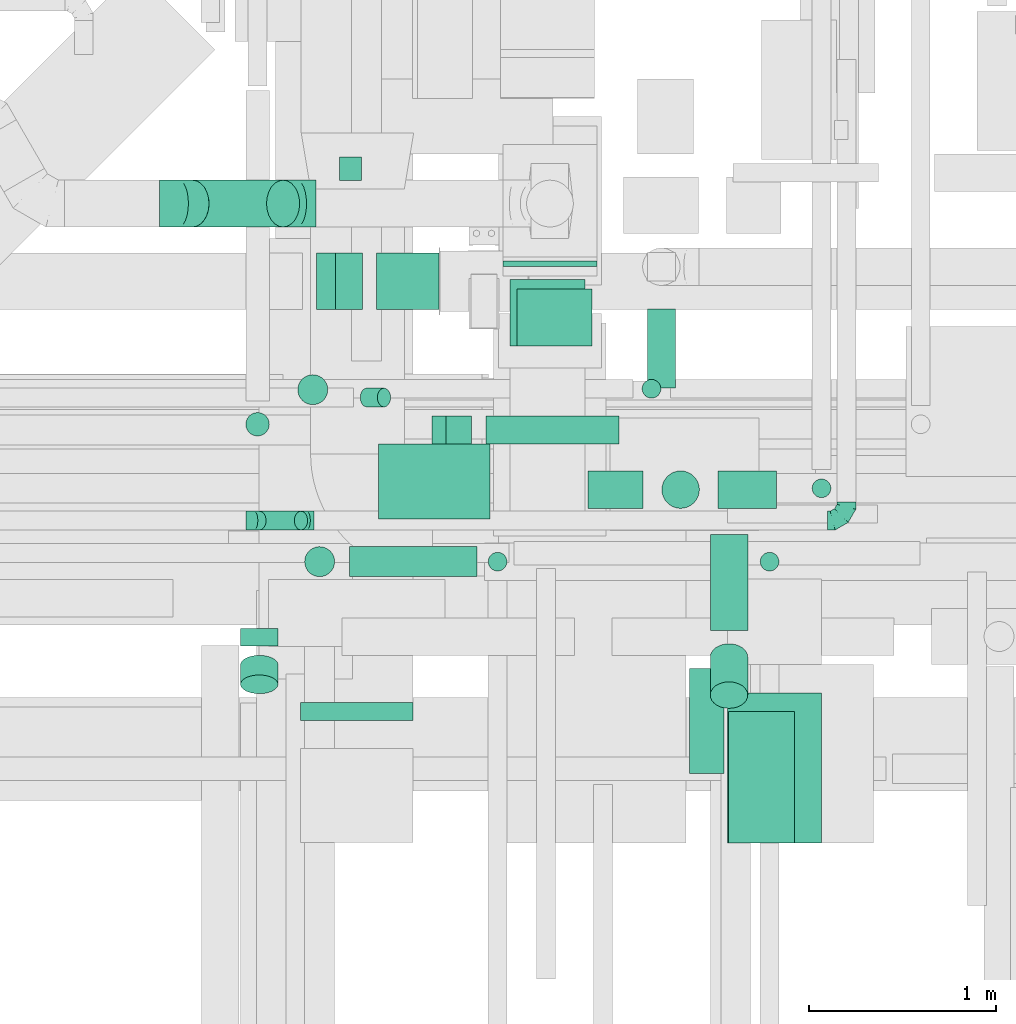
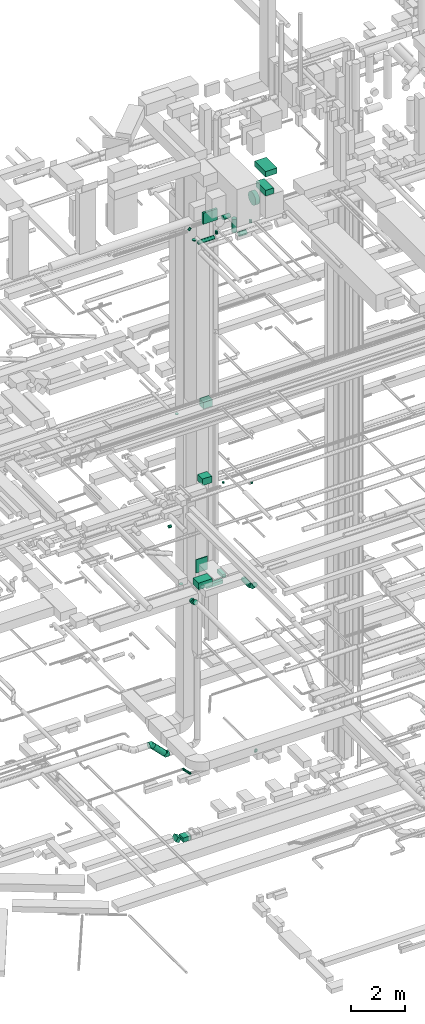
# One storey, part 128 of 337: 32 flow segments, 5 flow fittings.
"""IFC2X3 building model written with IfcOpenShell, lengths in millimetres."""

from ifc_helpers import new_model, entity, si_unit, converted_unit, derived_unit, direction, frame, frame_2d, origin, origin_2d_with_axis, place, context, subcontext, project, spatial, rectangle, circle, extrude, faceted_brep, source, transform, mapped, material, type_object, type_shapes, element, save


model = new_model("IFC2X3")

# Units and contexts
model_context = context("Model", 3, precision=0.01, world=origin(), true_north=direction((6.12303176911189e-17, 1.0)))
body_context = subcontext(model_context, "Body", "Model", "MODEL_VIEW")
ifc_project = project(units=[si_unit("LENGTHUNIT", "METRE", prefix="MILLI"), si_unit("AREAUNIT", "SQUARE_METRE"), si_unit("VOLUMEUNIT", "CUBIC_METRE"), converted_unit("PLANEANGLEUNIT", "DEGREE", entity("IfcRatioMeasure", 0.0174532925199433), si_unit("PLANEANGLEUNIT", "RADIAN"), dimensions=[0, 0, 0, 0, 0, 0, 0]), si_unit("MASSUNIT", "GRAM", prefix="KILO"), derived_unit("MASSDENSITYUNIT", [(si_unit("MASSUNIT", "GRAM", prefix="KILO"), 1), (si_unit("LENGTHUNIT", "METRE"), -3)]), derived_unit("MOMENTOFINERTIAUNIT", [(si_unit("LENGTHUNIT", "METRE"), 4)]), si_unit("TIMEUNIT", "SECOND"), si_unit("FREQUENCYUNIT", "HERTZ"), si_unit("THERMODYNAMICTEMPERATUREUNIT", "DEGREE_CELSIUS"), derived_unit("THERMALTRANSMITTANCEUNIT", [(si_unit("MASSUNIT", "GRAM", prefix="KILO"), 1), (si_unit("THERMODYNAMICTEMPERATUREUNIT", "KELVIN"), -1), (si_unit("TIMEUNIT", "SECOND"), -3)]), derived_unit("VOLUMETRICFLOWRATEUNIT", [(si_unit("LENGTHUNIT", "METRE"), 3), (si_unit("TIMEUNIT", "SECOND"), -1)]), derived_unit("MASSFLOWRATEUNIT", [(si_unit("MASSUNIT", "GRAM", prefix="KILO"), 1), (si_unit("TIMEUNIT", "SECOND"), -1)]), derived_unit("ROTATIONALFREQUENCYUNIT", [(si_unit("TIMEUNIT", "SECOND"), -1)]), si_unit("ELECTRICCURRENTUNIT", "AMPERE"), si_unit("ELECTRICVOLTAGEUNIT", "VOLT"), si_unit("POWERUNIT", "WATT"), si_unit("FORCEUNIT", "NEWTON", prefix="KILO"), si_unit("ILLUMINANCEUNIT", "LUX"), si_unit("LUMINOUSFLUXUNIT", "LUMEN"), si_unit("LUMINOUSINTENSITYUNIT", "CANDELA"), derived_unit("USERDEFINED", [(si_unit("MASSUNIT", "GRAM", prefix="KILO"), -1), (si_unit("LENGTHUNIT", "METRE"), -2), (si_unit("TIMEUNIT", "SECOND"), 3), (si_unit("LUMINOUSFLUXUNIT", "LUMEN"), 1)]), derived_unit("LINEARVELOCITYUNIT", [(si_unit("LENGTHUNIT", "METRE"), 1), (si_unit("TIMEUNIT", "SECOND"), -1)]), si_unit("PRESSUREUNIT", "PASCAL"), derived_unit("USERDEFINED", [(si_unit("LENGTHUNIT", "METRE"), -2), (si_unit("MASSUNIT", "GRAM", prefix="KILO"), 1), (si_unit("TIMEUNIT", "SECOND"), -2)]), derived_unit("LINEARFORCEUNIT", [(si_unit("MASSUNIT", "GRAM", prefix="KILO"), 1), (si_unit("LENGTHUNIT", "METRE"), 1), (si_unit("TIMEUNIT", "SECOND"), -2), (si_unit("LENGTHUNIT", "METRE"), -1)]), derived_unit("PLANARFORCEUNIT", [(si_unit("MASSUNIT", "GRAM", prefix="KILO"), 1), (si_unit("LENGTHUNIT", "METRE"), 1), (si_unit("TIMEUNIT", "SECOND"), -2), (si_unit("LENGTHUNIT", "METRE"), -2)])], contexts=[model_context])

# Site, building, storey
site_placement = place(None, origin())
site = spatial("IfcSite", under=ifc_project, at=site_placement, CompositionType="ELEMENT")
building_placement = place(site_placement, origin())
building = spatial("IfcBuilding", under=site, at=building_placement, CompositionType="ELEMENT")
storey_placement = place(building_placement, origin())
storey = spatial("IfcBuildingStorey", under=building, at=storey_placement, CompositionType="ELEMENT", Elevation=0.0)

# Flow segments
duct_segment_type_1 = type_object("IfcDuctSegmentType", PredefinedType="NOTDEFINED")
flow_segment_1_placement = place(storey_placement, frame((23416.99, 10670.0, -850.0)))
element("IfcFlowSegment", 1, at=flow_segment_1_placement, inside=storey, type_object=duct_segment_type_1, context=body_context, shape_type="SweptSolid", body=[
    extrude(rectangle(XDim=333.012703748609, YDim=300.000000000001, at=origin_2d_with_axis()), frame((166.51, 150.0, 0.0), z_axis=(0.0, 0.0, 1.0), x_axis=(-1.0, 0.0, 0.0)), (0.0, 0.0, 1.0), 200.0),
])
flow_segment_2_placement = place(storey_placement, frame((23427.3, 9550.83, 11250.0)))
element("IfcFlowSegment", 2, at=flow_segment_2_placement, inside=storey, type_object=duct_segment_type_1, context=body_context, shape_type="SweptSolid", body=[
    extrude(rectangle(XDim=594.99999999999, YDim=400.0, at=origin_2d_with_axis()), frame((297.5, 200.0, 0.0)), (0.0, 0.0, 1.0), 300.000000000001),
])
flow_segment_3_placement = place(storey_placement, frame((24861.21, 10251.69, 10850.0)))
element("IfcFlowSegment", 3, at=flow_segment_3_placement, inside=storey, type_object=duct_segment_type_1, context=body_context, shape_type="SweptSolid", body=[
    extrude(rectangle(XDim=420.860274633436, YDim=150.000000000001, at=origin_2d_with_axis()), frame((75.0, 210.43, 0.0), z_axis=(0.0, 0.0, 1.0), x_axis=(0.0, -1.0, 0.0)), (0.0, 0.0, 1.0), 150.000000000001),
])
flow_segment_4_placement = place(storey_placement, frame((23999.98, 9951.69, 10850.0)))
element("IfcFlowSegment", 4, at=flow_segment_4_placement, inside=storey, type_object=duct_segment_type_1, context=body_context, shape_type="SweptSolid", body=[
    extrude(rectangle(XDim=711.23519289757, YDim=150.000000000001, at=origin_2d_with_axis()), frame((355.62, 75.0, 0.0), z_axis=(0.0, 0.0, 1.0), x_axis=(-1.0, 0.0, 0.0)), (0.0, 0.0, 1.0), 150.000000000001),
])
flow_segment_5_placement = place(storey_placement, frame((24129.3, 10474.94, 15150.0)))
element("IfcFlowSegment", 5, at=flow_segment_5_placement, inside=storey, type_object=duct_segment_type_1, context=body_context, shape_type="SweptSolid", body=[
    extrude(rectangle(XDim=354.416495701594, YDim=400.0, at=origin_2d_with_axis()), frame((200.0, 177.21, 0.0), z_axis=(0.0, 0.0, 1.0), x_axis=(0.0, 1.0, 0.0)), (0.0, 0.0, 1.0), 300.000000000001),
])
flow_segment_6_placement = place(storey_placement, frame((24092.3, 10898.36, 10950.0)))
element("IfcFlowSegment", 6, at=flow_segment_6_placement, inside=storey, type_object=duct_segment_type_1, context=body_context, shape_type="SweptSolid", body=[
    extrude(rectangle(XDim=31.0000000000579, YDim=499.999999999999, at=origin_2d_with_axis()), frame((250.0, 15.5, 0.0), z_axis=(0.0, 0.0, 1.0), x_axis=(0.0, -1.0, 0.0)), (0.0, 0.0, 1.0), 600.000000000002),
])
flow_segment_7_placement = place(storey_placement, frame((24165.55, 10475.3, 18600.0)))
element("IfcFlowSegment", 7, at=flow_segment_7_placement, inside=storey, type_object=duct_segment_type_1, context=body_context, shape_type="SweptSolid", body=[
    extrude(rectangle(XDim=304.063774526682, YDim=400.0, at=origin_2d_with_axis()), frame((200.0, 152.03, 0.0), z_axis=(0.0, 0.0, 1.0), x_axis=(0.0, -1.0, 0.0)), (0.0, 0.0, 1.0), 300.000000000001),
])
flow_segment_8_placement = place(storey_placement, frame((23711.92, 9951.69, 10890.19)))
element("IfcFlowSegment", 8, at=flow_segment_8_placement, inside=storey, type_object=duct_segment_type_1, context=body_context, shape_type="SweptSolid", body=[
    extrude(rectangle(XDim=150.0, YDim=150.000000000001, at=origin_2d_with_axis()), frame((37.5, 75.0, 144.66), z_axis=(0.866025403784404, 0.0, -0.50000000000006), x_axis=(0.50000000000006, 0.0, 0.866025403784404)), (0.0, 0.0, 1.0), 159.422863405966),
])
flow_segment_9_placement = place(storey_placement, frame((23098.21, 10670.0, -803.11)))
element("IfcFlowSegment", 9, at=flow_segment_9_placement, inside=storey, type_object=duct_segment_type_1, context=body_context, shape_type="SweptSolid", body=[
    extrude(rectangle(XDim=200.000000000001, YDim=166.025414697291, at=frame_2d((0.0, 0.0), x_axis=(0.0, 1.0))), frame((121.89, 0.0, 128.11), z_axis=(0.0, 1.0, 0.0), x_axis=(-0.866025410712629, 0.0, 0.499999988000022)), (0.0, 0.0, 1.0), 300.000000000001),
])
duct_segment_type_2 = type_object("IfcDuctSegmentType", PredefinedType="NOTDEFINED")
flow_segment_10_placement = place(storey_placement, frame((22995.7, 10159.92, 11225.0)))
element("IfcFlowSegment", 10, at=flow_segment_10_placement, inside=storey, type_object=duct_segment_type_2, context=body_context, shape_type="SweptSolid", body=[
    extrude(circle(Radius=80.0, at=origin_2d_with_axis()), frame((81.6, 81.6, 0.0), z_axis=(0.0, 0.0, 1.0), x_axis=(0.0, 1.0, 0.0)), (0.0, 0.0, 1.0), 4.99999999988408),
])
flow_segment_11_placement = place(storey_placement, frame((22345.36, 11107.76, 2953.24)))
element("IfcFlowSegment", 11, at=flow_segment_11_placement, inside=storey, type_object=duct_segment_type_2, context=body_context, shape_type="SweptSolid", body=[
    extrude(circle(Radius=125.0, at=origin_2d_with_axis()), frame((573.54, 126.6, 89.98), z_axis=(-0.707106781186545, 0.0, 0.70710678118655), x_axis=(0.0, -1.0, 0.0)), (0.0, 0.0, 1.0), 683.847763108508),
])
flow_segment_12_placement = place(storey_placement, frame((22690.22, 8874.74, 11254.41)))
element("IfcFlowSegment", 12, at=flow_segment_12_placement, inside=storey, type_object=duct_segment_type_2, context=body_context, shape_type="SweptSolid", body=[
    extrude(circle(Radius=100.0, at=origin_2d_with_axis()), frame((101.6, 0.0, 101.6), z_axis=(0.0, 1.0, 0.0), x_axis=(-1.0, 0.0, 0.0)), (0.0, 0.0, 1.0), 93.1351932953009),
])
flow_segment_13_placement = place(storey_placement, frame((22690.22, 8618.52, 11294.6)))
element("IfcFlowSegment", 13, at=flow_segment_13_placement, inside=storey, type_object=duct_segment_type_2, context=body_context, shape_type="SweptSolid", body=[
    extrude(circle(Radius=100.0, at=origin_2d_with_axis()), frame((101.6, 156.22, 88.2), z_axis=(0.0, -0.86602530090874, 0.500000178185895), x_axis=(-1.0, 0.0, 0.0)), (0.0, 0.0, 1.0), 120.810096405886),
])
flow_segment_14_placement = place(storey_placement, frame((25195.7, 8956.91, 11048.4)))
element("IfcFlowSegment", 14, at=flow_segment_14_placement, inside=storey, type_object=duct_segment_type_2, context=body_context, shape_type="SweptSolid", body=[
    extrude(circle(Radius=100.0, at=origin_2d_with_axis()), frame((101.6, 0.0, 101.6), z_axis=(0.0, 1.0, 0.0), x_axis=(-1.0, 0.0, 0.0)), (0.0, 0.0, 1.0), 513.631879125135),
])
flow_segment_15_placement = place(storey_placement, frame((25195.7, 8540.34, 11136.27)))
element("IfcFlowSegment", 15, at=flow_segment_15_placement, inside=storey, type_object=duct_segment_type_2, context=body_context, shape_type="SweptSolid", body=[
    extrude(circle(Radius=100.0, at=origin_2d_with_axis()), frame((101.6, 275.15, 72.31), z_axis=(0.0, -0.707106781186528, 0.707106781186567), x_axis=(-1.0, 0.0, 0.0)), (0.0, 0.0, 1.0), 286.862915010188),
])
flow_segment_16_placement = place(storey_placement, frame((23219.15, 11355.44, 12973.4)))
element("IfcFlowSegment", 16, at=flow_segment_16_placement, inside=storey, type_object=duct_segment_type_2, context=body_context, shape_type="SweptSolid", body=[
    extrude(circle(Radius=62.5, at=origin_2d_with_axis()), frame((0.0, 64.1, 64.1), z_axis=(1.0, 0.0, 0.0), x_axis=(0.0, 1.0, 0.0)), (0.0, 0.0, 1.0), 117.499999999999),
])
flow_segment_17_placement = place(storey_placement, frame((24832.43, 10194.7, 15150.0)))
element("IfcFlowSegment", 17, at=flow_segment_17_placement, inside=storey, type_object=duct_segment_type_2, context=body_context, shape_type="SweptSolid", body=[
    extrude(circle(Radius=50.0, at=origin_2d_with_axis()), frame((51.6, 51.6, 0.0), z_axis=(0.0, 0.0, 1.0), x_axis=(0.0, -1.0, 0.0)), (0.0, 0.0, 1.0), 49.999999999993),
])
flow_segment_18_placement = place(storey_placement, frame((25739.15, 9664.09, 15150.0)))
element("IfcFlowSegment", 18, at=flow_segment_18_placement, inside=storey, type_object=duct_segment_type_2, context=body_context, shape_type="SweptSolid", body=[
    extrude(circle(Radius=50.0, at=origin_2d_with_axis()), frame((51.6, 51.6, 0.0)), (0.0, 0.0, 1.0), 49.9999996080384),
])
flow_segment_19_placement = place(storey_placement, frame((22718.49, 9993.02, 19110.0)))
element("IfcFlowSegment", 19, at=flow_segment_19_placement, inside=storey, type_object=duct_segment_type_2, context=body_context, shape_type="SweptSolid", body=[
    extrude(circle(Radius=62.5, at=origin_2d_with_axis()), frame((64.1, 64.1, 0.0), z_axis=(0.0, 0.0, 1.0), x_axis=(-1.0, 0.0, 0.0)), (0.0, 0.0, 1.0), 39.9999999999346),
])
flow_segment_20_placement = place(storey_placement, frame((24545.26, 9606.98, 27498.4)))
element("IfcFlowSegment", 20, at=flow_segment_20_placement, inside=storey, type_object=duct_segment_type_2, context=body_context, shape_type="SweptSolid", body=[
    extrude(circle(Radius=100.0, at=origin_2d_with_axis()), frame((0.0, 101.6, 101.6), z_axis=(1.0, 0.0, 0.0), x_axis=(0.0, -1.0, 0.0)), (0.0, 0.0, 1.0), 294.040820577332),
])
flow_segment_21_placement = place(storey_placement, frame((24937.7, 9606.98, 26800.0)))
element("IfcFlowSegment", 21, at=flow_segment_21_placement, inside=storey, type_object=duct_segment_type_2, context=body_context, shape_type="SweptSolid", body=[
    extrude(circle(Radius=100.0, at=origin_2d_with_axis()), frame((101.6, 101.6, 0.0), z_axis=(0.0, 0.0, 1.0), x_axis=(0.0, -1.0, 0.0)), (0.0, 0.0, 1.0), 600.000000000006),
])
flow_segment_22_placement = place(storey_placement, frame((25239.3, 9606.98, 26498.4)))
element("IfcFlowSegment", 22, at=flow_segment_22_placement, inside=storey, type_object=duct_segment_type_2, context=body_context, shape_type="SweptSolid", body=[
    extrude(circle(Radius=100.0, at=origin_2d_with_axis()), frame((0.0, 101.6, 101.6), z_axis=(1.0, 0.0, 0.0), x_axis=(0.0, -1.0, 0.0)), (0.0, 0.0, 1.0), 310.000000000003),
])
flow_segment_23_placement = place(storey_placement, frame((23273.85, 9242.81, 27068.4)))
element("IfcFlowSegment", 23, at=flow_segment_23_placement, inside=storey, type_object=duct_segment_type_2, context=body_context, shape_type="SweptSolid", body=[
    extrude(circle(Radius=80.0, at=origin_2d_with_axis()), frame((0.0, 81.6, 81.6), z_axis=(1.0, 0.0, 0.0), x_axis=(0.0, 1.0, 0.0)), (0.0, 0.0, 1.0), 680.000000000014),
])
flow_segment_24_placement = place(storey_placement, frame((25087.42, 8193.01, 28742.4)))
element("IfcFlowSegment", 24, at=flow_segment_24_placement, inside=storey, type_object=duct_segment_type_2, context=body_context, shape_type="SweptSolid", body=[
    extrude(circle(Radius=280.0, at=origin_2d_with_axis()), frame((0.0, 281.6, 281.6), z_axis=(1.0, 0.0, 0.0), x_axis=(0.0, 1.0, 0.0)), (0.0, 0.0, 1.0), 181.87272947957),
])
flow_segment_25_placement = place(storey_placement, frame((22755.78, 9491.98, 3092.34)))
element("IfcFlowSegment", 25, at=flow_segment_25_placement, inside=storey, type_object=duct_segment_type_2, context=body_context, shape_type="SweptSolid", body=[
    extrude(circle(Radius=50.0, at=origin_2d_with_axis()), frame((258.37, 51.6, 36.95), z_axis=(-0.707106781186546, 0.0, 0.707106781186549), x_axis=(0.0, -1.0, 0.0)), (0.0, 0.0, 1.0), 313.137084989808),
])
flow_segment_26_placement = place(storey_placement, frame((25462.09, 9272.81, 27270.0)))
element("IfcFlowSegment", 26, at=flow_segment_26_placement, inside=storey, type_object=duct_segment_type_2, context=body_context, shape_type="SweptSolid", body=[
    extrude(circle(Radius=50.0, at=origin_2d_with_axis()), frame((51.6, 51.6, 0.0), z_axis=(0.0, 0.0, 1.0), x_axis=(-1.0, 0.0, 0.0)), (0.0, 0.0, 1.0), 129.999999999996),
])
flow_segment_27_placement = place(storey_placement, frame((24011.34, 9272.81, 27270.0)))
element("IfcFlowSegment", 27, at=flow_segment_27_placement, inside=storey, type_object=duct_segment_type_2, context=body_context, shape_type="SweptSolid", body=[
    extrude(circle(Radius=50.0, at=origin_2d_with_axis()), frame((51.6, 51.6, 0.0), z_axis=(0.0, 0.0, 1.0), x_axis=(-1.0, 0.0, 0.0)), (0.0, 0.0, 1.0), 130.000000000005),
])
flow_segment_28_placement = place(storey_placement, frame((23032.26, 9242.81, 27310.0)))
element("IfcFlowSegment", 28, at=flow_segment_28_placement, inside=storey, type_object=duct_segment_type_2, context=body_context, shape_type="SweptSolid", body=[
    extrude(circle(Radius=80.0, at=origin_2d_with_axis()), frame((81.6, 81.6, 0.0), z_axis=(0.0, 0.0, 1.0), x_axis=(-1.0, 0.0, 0.0)), (0.0, 0.0, 1.0), 30.0000000000452),
])
flow_segment_29_placement = place(storey_placement, frame((23328.79, 10148.35, 27092.34)))
element("IfcFlowSegment", 29, at=flow_segment_29_placement, inside=storey, type_object=duct_segment_type_2, context=body_context, shape_type="SweptSolid", body=[
    extrude(circle(Radius=50.0, at=origin_2d_with_axis()), frame((36.95, 51.6, 36.95), z_axis=(0.707106781186548, 0.0, 0.707106781186548), x_axis=(0.0, -1.0, 0.0)), (0.0, 0.0, 1.0), 129.289321881363),
])
duct_segment_type_3 = type_object("IfcDuctSegmentType", PredefinedType="NOTDEFINED")
flow_segment_30_placement = place(storey_placement, frame((25290.29, 7824.6, 30300.0)))
element("IfcFlowSegment", 30, at=flow_segment_30_placement, inside=storey, type_object=duct_segment_type_3, context=body_context, shape_type="SweptSolid", body=[
    extrude(rectangle(XDim=499.999999999999, YDim=800.0, at=origin_2d_with_axis()), frame((250.0, 400.0, 0.0)), (0.0, 0.0, 1.0), 250.00005000012),
])
flow_segment_31_placement = place(storey_placement, frame((25295.29, 7824.6, 29445.0)))
element("IfcFlowSegment", 31, at=flow_segment_31_placement, inside=storey, type_object=duct_segment_type_3, context=body_context, shape_type="SweptSolid", body=[
    extrude(rectangle(XDim=349.999999999998, YDim=700.0, at=origin_2d_with_axis()), frame((175.0, 350.0, 0.0)), (0.0, 0.0, 1.0), 254.999974999893),
])
flow_segment_32_placement = place(storey_placement, frame((23012.03, 8476.61, 28572.0)))
element("IfcFlowSegment", 32, at=flow_segment_32_placement, inside=storey, type_object=duct_segment_type_3, context=body_context, shape_type="SweptSolid", body=[
    extrude(rectangle(XDim=95.9884638510038, YDim=599.999999999998, at=origin_2d_with_axis()), frame((300.0, 47.99, 0.0), z_axis=(0.0, 0.0, 1.0), x_axis=(0.0, 1.0, 0.0)), (0.0, 0.0, 1.0), 499.999999999999),
])

# Flow fittings
ifc_material = material()
duct_fitting_type_1 = type_object("IfcDuctFittingType", PredefinedType="NOTDEFINED", material=ifc_material)
shared_shape_1 = source(origin(), body_context, "Body", "Brep", [
    faceted_brep([(-100.0, 0.0, -50.0), (-100.0, -12.94, -48.3), (-100.0, -25.0, -43.3), (-100.0, -35.36, -35.36), (-100.0, -43.3, -25.0), (-100.0, -48.3, -12.94), (-100.0, -50.0, 0.0), (-100.0, -48.3, 12.94), (-100.0, -43.3, 25.0), (-100.0, -35.36, 35.36), (-100.0, -25.0, 43.3), (-100.0, -12.94, 48.3), (-100.0, 0.0, 50.0), (-100.0, 12.94, 48.3), (-100.0, 25.0, 43.3), (-100.0, 35.36, 35.36), (-100.0, 43.3, 25.0), (-100.0, 48.3, 12.94), (-100.0, 50.0, 0.0), (-100.0, 48.3, -12.94), (-100.0, 43.3, -25.0), (-100.0, 35.36, -35.36), (-100.0, 25.0, -43.3), (-100.0, 12.94, -48.3), (-76.67, 12.94, 48.3), (-79.9, 25.0, 43.3), (-73.21, 0.0, 50.0), (-82.68, 35.36, 35.36), (-86.15, 48.3, 12.94), (-86.6, 50.0, 0.0), (-84.81, 43.3, 25.0), (-84.81, 43.3, -25.0), (-82.68, 35.36, -35.36), (-86.15, 48.3, -12.94), (-76.67, 12.94, -48.3), (-73.21, 0.0, -50.0), (-79.9, 25.0, -43.3), (-69.74, -12.94, -48.3), (-66.51, -25.0, -43.3), (-63.73, -35.36, -35.36), (-61.6, -43.3, -25.0), (-60.26, -48.3, -12.94), (-59.81, -50.0, 0.0), (-60.26, -48.3, 12.94), (-61.6, -43.3, 25.0), (-63.73, -35.36, 35.36), (-66.51, -25.0, 43.3), (-69.74, -12.94, 48.3), (-36.27, 36.27, 48.3), (-45.1, 45.1, 43.3), (-26.79, 26.79, 50.0), (-52.68, 52.68, 35.36), (-58.49, 58.49, 25.0), (-62.15, 62.15, 12.94), (-63.4, 63.4, 0.0), (-62.15, 62.15, -12.94), (-58.49, 58.49, -25.0), (-52.68, 52.68, -35.36), (-36.27, 36.27, -48.3), (-26.79, 26.79, -50.0), (-45.1, 45.1, -43.3), (-17.32, 17.32, -48.3), (-8.49, 8.49, -43.3), (-0.91, 0.91, -35.36), (4.9, -4.9, -25.0), (8.56, -8.56, -12.94), (9.81, -9.81, 0.0), (8.56, -8.56, 12.94), (4.9, -4.9, 25.0), (-0.91, 0.91, 35.36), (-8.49, 8.49, 43.3), (-17.32, 17.32, 48.3), (-12.94, 76.67, 48.3), (-25.0, 79.9, 43.3), (0.0, 73.21, 50.0), (-35.36, 82.68, 35.36), (-43.3, 84.81, 25.0), (-48.3, 86.15, 12.94), (-50.0, 86.6, 0.0), (-48.3, 86.15, -12.94), (-43.3, 84.81, -25.0), (-35.36, 82.68, -35.36), (-12.94, 76.67, -48.3), (0.0, 73.21, -50.0), (-25.0, 79.9, -43.3), (12.94, 69.74, -48.3), (25.0, 66.51, -43.3), (35.36, 63.73, -35.36), (43.3, 61.6, -25.0), (48.3, 60.26, -12.94), (50.0, 59.81, 0.0), (48.3, 60.26, 12.94), (43.3, 61.6, 25.0), (35.36, 63.73, 35.36), (25.0, 66.51, 43.3), (12.94, 69.74, 48.3), (-12.94, 100.0, -48.3), (-25.0, 100.0, -43.3), (-35.36, 100.0, -35.36), (-43.3, 100.0, -25.0), (-48.3, 100.0, -12.94), (-50.0, 100.0, 0.0), (-48.3, 100.0, 12.94), (-43.3, 100.0, 25.0), (-35.36, 100.0, 35.36), (-25.0, 100.0, 43.3), (-12.94, 100.0, 48.3), (0.0, 100.0, 50.0), (12.94, 100.0, 48.3), (25.0, 100.0, 43.3), (35.36, 100.0, 35.36), (43.3, 100.0, 25.0), (48.3, 100.0, 12.94), (50.0, 100.0, 0.0), (48.3, 100.0, -12.94), (43.3, 100.0, -25.0), (35.36, 100.0, -35.36), (25.0, 100.0, -43.3), (12.94, 100.0, -48.3), (0.0, 100.0, -50.0)], [[[0, 1, 2, 3, 4, 5, 6, 7, 8, 9, 10, 11, 12, 13, 14, 15, 16, 17, 18, 19, 20, 21, 22, 23]], [[24, 25, 14, 13]], [[26, 24, 13, 12]], [[14, 25, 27, 15]], [[28, 29, 18, 17]], [[30, 28, 17, 16]], [[15, 27, 30, 16]], [[20, 31, 32, 21]], [[33, 31, 20, 19]], [[18, 29, 33, 19]], [[34, 35, 0, 23]], [[36, 34, 23, 22]], [[32, 36, 22, 21]], [[2, 1, 37, 38]], [[3, 2, 38, 39]], [[0, 35, 37, 1]], [[5, 4, 40, 41]], [[6, 5, 41, 42]], [[3, 39, 40, 4]], [[6, 42, 43, 7]], [[7, 43, 44, 8]], [[8, 44, 45, 9]], [[10, 46, 47, 11]], [[11, 47, 26, 12]], [[10, 9, 45, 46]], [[48, 49, 25, 24]], [[50, 48, 24, 26]], [[27, 25, 49, 51]], [[52, 53, 28, 30]], [[51, 52, 30, 27]], [[29, 28, 53, 54]], [[55, 56, 31, 33]], [[54, 55, 33, 29]], [[57, 32, 31, 56]], [[58, 59, 35, 34]], [[60, 58, 34, 36]], [[57, 60, 36, 32]], [[37, 35, 59, 61]], [[38, 37, 61, 62]], [[39, 38, 62, 63]], [[41, 40, 64, 65]], [[42, 41, 65, 66]], [[63, 64, 40, 39]], [[43, 42, 66, 67]], [[44, 43, 67, 68]], [[68, 69, 45, 44]], [[46, 45, 69, 70]], [[47, 46, 70, 71]], [[26, 47, 71, 50]], [[72, 73, 49, 48]], [[74, 72, 48, 50]], [[51, 49, 73, 75]], [[76, 77, 53, 52]], [[75, 76, 52, 51]], [[54, 53, 77, 78]], [[79, 80, 56, 55]], [[78, 79, 55, 54]], [[81, 57, 56, 80]], [[82, 83, 59, 58]], [[84, 82, 58, 60]], [[81, 84, 60, 57]], [[61, 59, 83, 85]], [[62, 61, 85, 86]], [[63, 62, 86, 87]], [[65, 64, 88, 89]], [[66, 65, 89, 90]], [[87, 88, 64, 63]], [[67, 66, 90, 91]], [[68, 67, 91, 92]], [[92, 93, 69, 68]], [[70, 69, 93, 94]], [[71, 70, 94, 95]], [[50, 71, 95, 74]], [[96, 97, 98, 99, 100, 101, 102, 103, 104, 105, 106, 107, 108, 109, 110, 111, 112, 113, 114, 115, 116, 117, 118, 119]], [[72, 74, 107, 106]], [[73, 72, 106, 105]], [[75, 73, 105, 104]], [[77, 76, 103, 102]], [[78, 77, 102, 101]], [[75, 104, 103, 76]], [[78, 101, 100, 79]], [[79, 100, 99, 80]], [[80, 99, 98, 81]], [[96, 119, 83, 82]], [[97, 96, 82, 84]], [[84, 81, 98, 97]], [[83, 119, 118, 85]], [[85, 118, 117, 86]], [[86, 117, 116, 87]], [[88, 115, 114, 89]], [[89, 114, 113, 90]], [[87, 116, 115, 88]], [[91, 90, 113, 112]], [[92, 91, 112, 111]], [[93, 92, 111, 110]], [[95, 94, 109, 108]], [[74, 95, 108, 107]], [[110, 109, 94, 93]]]),
])
type_shapes(duct_fitting_type_1, [shared_shape_1])
flow_fitting_placement = place(storey_placement, frame((25923.44, 9543.58, 3100.0)))
element("IfcFlowFitting", 33, at=flow_fitting_placement, inside=storey, type_object=duct_fitting_type_1, material=ifc_material, context=body_context, shape_type="MappedRepresentation", body=[
    mapped(shared_shape_1, transform((0.0, 0.0, 0.0), scale=1.0)),
])
duct_fitting_type_2 = type_object("IfcDuctFittingType", PredefinedType="NOTDEFINED", material=ifc_material)
shared_shape_2 = source(origin(), body_context, "Body", "Brep", [
    faceted_brep([(-41.42, 0.0, -50.0), (-41.42, -12.94, -48.3), (-41.42, -25.0, -43.3), (-41.42, -35.36, -35.36), (-41.42, -43.3, -25.0), (-41.42, -48.3, -12.94), (-41.42, -50.0, 0.0), (-41.42, -48.3, 12.94), (-41.42, -43.3, 25.0), (-41.42, -35.36, 35.36), (-41.42, -25.0, 43.3), (-41.42, -12.94, 48.3), (-41.42, 0.0, 50.0), (-41.42, 12.94, 48.3), (-41.42, 25.0, 43.3), (-41.42, 35.36, 35.36), (-41.42, 43.3, 25.0), (-41.42, 48.3, 12.94), (-41.42, 50.0, 0.0), (-41.42, 48.3, -12.94), (-41.42, 43.3, -25.0), (-41.42, 35.36, -35.36), (-41.42, 25.0, -43.3), (-41.42, 12.94, -48.3), (-5.36, 12.94, 48.3), (-10.36, 25.0, 43.3), (0.0, 0.0, 50.0), (-14.64, 35.36, 35.36), (-20.0, 48.3, 12.94), (-20.71, 50.0, 0.0), (-17.94, 43.3, 25.0), (-17.94, 43.3, -25.0), (-14.64, 35.36, -35.36), (-20.0, 48.3, -12.94), (-5.36, 12.94, -48.3), (0.0, 0.0, -50.0), (-10.36, 25.0, -43.3), (5.36, -12.94, -48.3), (10.36, -25.0, -43.3), (14.64, -35.36, -35.36), (17.94, -43.3, -25.0), (20.0, -48.3, -12.94), (20.71, -50.0, 0.0), (20.0, -48.3, 12.94), (17.94, -43.3, 25.0), (14.64, -35.36, 35.36), (10.36, -25.0, 43.3), (5.36, -12.94, 48.3), (29.29, 29.29, 50.0), (20.14, 38.44, 48.3), (11.61, 46.97, 43.3), (4.29, 54.29, 35.36), (-1.33, 59.91, 25.0), (-4.86, 63.44, 12.94), (-6.07, 64.64, 0.0), (-4.86, 63.44, -12.94), (-1.33, 59.91, -25.0), (4.29, 54.29, -35.36), (11.61, 46.97, -43.3), (20.14, 38.44, -48.3), (29.29, 29.29, -50.0), (38.44, 20.14, -48.3), (46.97, 11.61, -43.3), (54.29, 4.29, -35.36), (59.91, -1.33, -25.0), (63.44, -4.86, -12.94), (64.64, -6.07, 0.0), (63.44, -4.86, 12.94), (59.91, -1.33, 25.0), (54.29, 4.29, 35.36), (46.97, 11.61, 43.3), (38.44, 20.14, 48.3)], [[[0, 1, 2, 3, 4, 5, 6, 7, 8, 9, 10, 11, 12, 13, 14, 15, 16, 17, 18, 19, 20, 21, 22, 23]], [[24, 25, 14, 13]], [[26, 24, 13, 12]], [[14, 25, 27, 15]], [[28, 29, 18, 17]], [[30, 28, 17, 16]], [[16, 15, 27, 30]], [[20, 31, 32, 21]], [[33, 31, 20, 19]], [[18, 29, 33, 19]], [[34, 35, 0, 23]], [[36, 34, 23, 22]], [[32, 36, 22, 21]], [[1, 0, 35, 37]], [[2, 1, 37, 38]], [[38, 39, 3, 2]], [[5, 4, 40, 41]], [[6, 5, 41, 42]], [[39, 40, 4, 3]], [[6, 42, 43, 7]], [[7, 43, 44, 8]], [[8, 44, 45, 9]], [[9, 45, 46, 10]], [[10, 46, 47, 11]], [[26, 12, 11, 47]], [[24, 26, 48, 49]], [[25, 24, 49, 50]], [[27, 25, 50, 51]], [[28, 30, 52, 53]], [[29, 28, 53, 54]], [[27, 51, 52, 30]], [[29, 54, 55, 33]], [[33, 55, 56, 31]], [[31, 56, 57, 32]], [[36, 58, 59, 34]], [[34, 59, 60, 35]], [[36, 32, 57, 58]], [[61, 62, 38, 37]], [[60, 61, 37, 35]], [[63, 39, 38, 62]], [[40, 64, 65, 41]], [[41, 65, 66, 42]], [[64, 40, 39, 63]], [[43, 42, 66, 67]], [[44, 43, 67, 68]], [[68, 69, 45, 44]], [[47, 46, 70, 71]], [[26, 47, 71, 48]], [[69, 70, 46, 45]], [[59, 58, 57, 56, 55, 54, 53, 52, 51, 50, 49, 48, 71, 70, 69, 68, 67, 66, 65, 64, 63, 62, 61, 60]]]),
])
type_shapes(duct_fitting_type_2, [shared_shape_2])
for number, where, z_axis, x_axis in (
    (34, (22763.44, 9543.58, 3380.0), (0.0, 1.0, 0.0), (1.0, 0.0, 0.0)),
    (35, (23043.44, 9543.58, 3100.0), (0.0, -1.0, 0.0), (0.707106781186508, 0.0, -0.707106781186587)),
):
    element("IfcFlowFitting", number, at=place(storey_placement, frame(where, z_axis=z_axis, x_axis=x_axis)), inside=storey, type_object=duct_fitting_type_2, material=ifc_material, context=body_context, shape_type="MappedRepresentation", body=[
        mapped(shared_shape_2, transform((0.0, 0.0, 0.0), scale=1.0)),
    ])
duct_fitting_type_3 = type_object("IfcDuctFittingType", PredefinedType="NOTDEFINED", material=ifc_material)
shared_shape_3 = source(origin(), body_context, "Body", "Brep", [
    faceted_brep([(-103.55, 0.0, -125.0), (-103.55, -32.35, -120.74), (-103.55, -62.5, -108.25), (-103.55, -88.39, -88.39), (-103.55, -108.25, -62.5), (-103.55, -120.74, -32.35), (-103.55, -125.0, 0.0), (-103.55, -120.74, 32.35), (-103.55, -108.25, 62.5), (-103.55, -88.39, 88.39), (-103.55, -62.5, 108.25), (-103.55, -32.35, 120.74), (-103.55, 0.0, 125.0), (-103.55, 32.35, 120.74), (-103.55, 62.5, 108.25), (-103.55, 88.39, 88.39), (-103.55, 108.25, 62.5), (-103.55, 120.74, 32.35), (-103.55, 125.0, 0.0), (-103.55, 120.74, -32.35), (-103.55, 108.25, -62.5), (-103.55, 88.39, -88.39), (-103.55, 62.5, -108.25), (-103.55, 32.35, -120.74), (-13.4, 32.35, 120.74), (-25.89, 62.5, 108.25), (0.0, 0.0, 125.0), (-36.61, 88.39, 88.39), (-44.84, 108.25, 62.5), (-50.01, 120.74, 32.35), (-51.78, 125.0, 0.0), (-50.01, 120.74, -32.35), (-44.84, 108.25, -62.5), (-36.61, 88.39, -88.39), (-13.4, 32.35, -120.74), (0.0, 0.0, -125.0), (-25.89, 62.5, -108.25), (13.4, -32.35, -120.74), (25.89, -62.5, -108.25), (36.61, -88.39, -88.39), (44.84, -108.25, -62.5), (50.01, -120.74, -32.35), (51.78, -125.0, 0.0), (50.01, -120.74, 32.35), (44.84, -108.25, 62.5), (36.61, -88.39, 88.39), (25.89, -62.5, 108.25), (13.4, -32.35, 120.74), (73.22, 73.22, 125.0), (50.35, 96.1, 120.74), (29.03, 117.42, 108.25), (10.72, 135.72, 88.39), (-3.32, 149.77, 62.5), (-12.15, 158.6, 32.35), (-15.17, 161.61, 0.0), (-12.15, 158.6, -32.35), (-3.32, 149.77, -62.5), (10.72, 135.72, -88.39), (29.03, 117.42, -108.25), (50.35, 96.1, -120.74), (73.22, 73.22, -125.0), (96.1, 50.35, -120.74), (117.42, 29.03, -108.25), (135.72, 10.72, -88.39), (149.77, -3.32, -62.5), (158.6, -12.15, -32.35), (161.61, -15.17, 0.0), (158.6, -12.15, 32.35), (149.77, -3.32, 62.5), (135.72, 10.72, 88.39), (117.42, 29.03, 108.25), (96.1, 50.35, 120.74)], [[[0, 1, 2, 3, 4, 5, 6, 7, 8, 9, 10, 11, 12, 13, 14, 15, 16, 17, 18, 19, 20, 21, 22, 23]], [[24, 25, 14, 13]], [[26, 24, 13, 12]], [[14, 25, 27, 15]], [[28, 29, 17, 16]], [[28, 16, 15, 27]], [[30, 18, 17, 29]], [[31, 32, 20, 19]], [[30, 31, 19, 18]], [[32, 33, 21, 20]], [[34, 35, 0, 23]], [[36, 34, 23, 22]], [[33, 36, 22, 21]], [[1, 0, 35, 37]], [[2, 1, 37, 38]], [[38, 39, 3, 2]], [[5, 4, 40, 41]], [[6, 5, 41, 42]], [[39, 40, 4, 3]], [[6, 42, 43, 7]], [[7, 43, 44, 8]], [[8, 44, 45, 9]], [[9, 45, 46, 10]], [[10, 46, 47, 11]], [[26, 12, 11, 47]], [[24, 26, 48, 49]], [[25, 24, 49, 50]], [[27, 25, 50, 51]], [[29, 28, 52, 53]], [[30, 29, 53, 54]], [[51, 52, 28, 27]], [[30, 54, 55, 31]], [[31, 55, 56, 32]], [[57, 33, 32, 56]], [[36, 58, 59, 34]], [[34, 59, 60, 35]], [[58, 36, 33, 57]], [[35, 60, 61, 37]], [[37, 61, 62, 38]], [[63, 39, 38, 62]], [[40, 64, 65, 41]], [[41, 65, 66, 42]], [[64, 40, 39, 63]], [[43, 42, 66, 67]], [[44, 43, 67, 68]], [[68, 69, 45, 44]], [[47, 46, 70, 71]], [[26, 47, 71, 48]], [[69, 70, 46, 45]], [[59, 58, 57, 56, 55, 54, 53, 52, 51, 50, 49, 48, 71, 70, 69, 68, 67, 66, 65, 64, 63, 62, 61, 60]]]),
])
type_shapes(duct_fitting_type_3, [shared_shape_3])
for number, where, z_axis, x_axis in (
    (36, (22362.12, 11234.36, 3600.0), (0.0, 1.0, 0.0), (1.0, 0.0, 0.0)),
    (37, (22992.12, 11234.36, 2970.0), (0.0, 1.0, 0.0), (-1.0, 0.0, 0.0)),
):
    element("IfcFlowFitting", number, at=place(storey_placement, frame(where, z_axis=z_axis, x_axis=x_axis)), inside=storey, type_object=duct_fitting_type_3, material=ifc_material, context=body_context, shape_type="MappedRepresentation", body=[
        mapped(shared_shape_3, transform((0.0, 0.0, 0.0), scale=1.0)),
    ])

save(model, "model.ifc")
